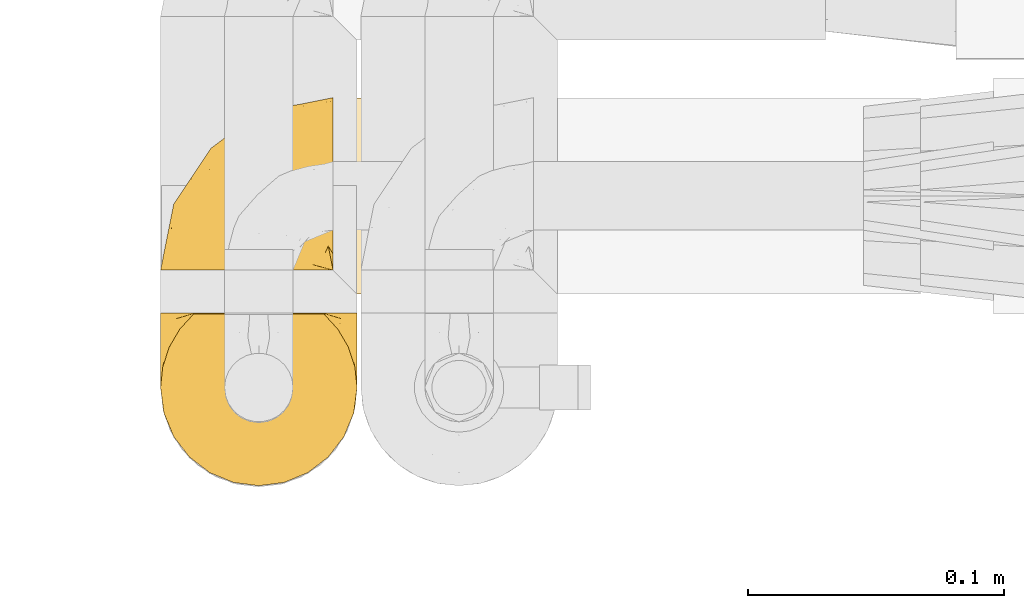
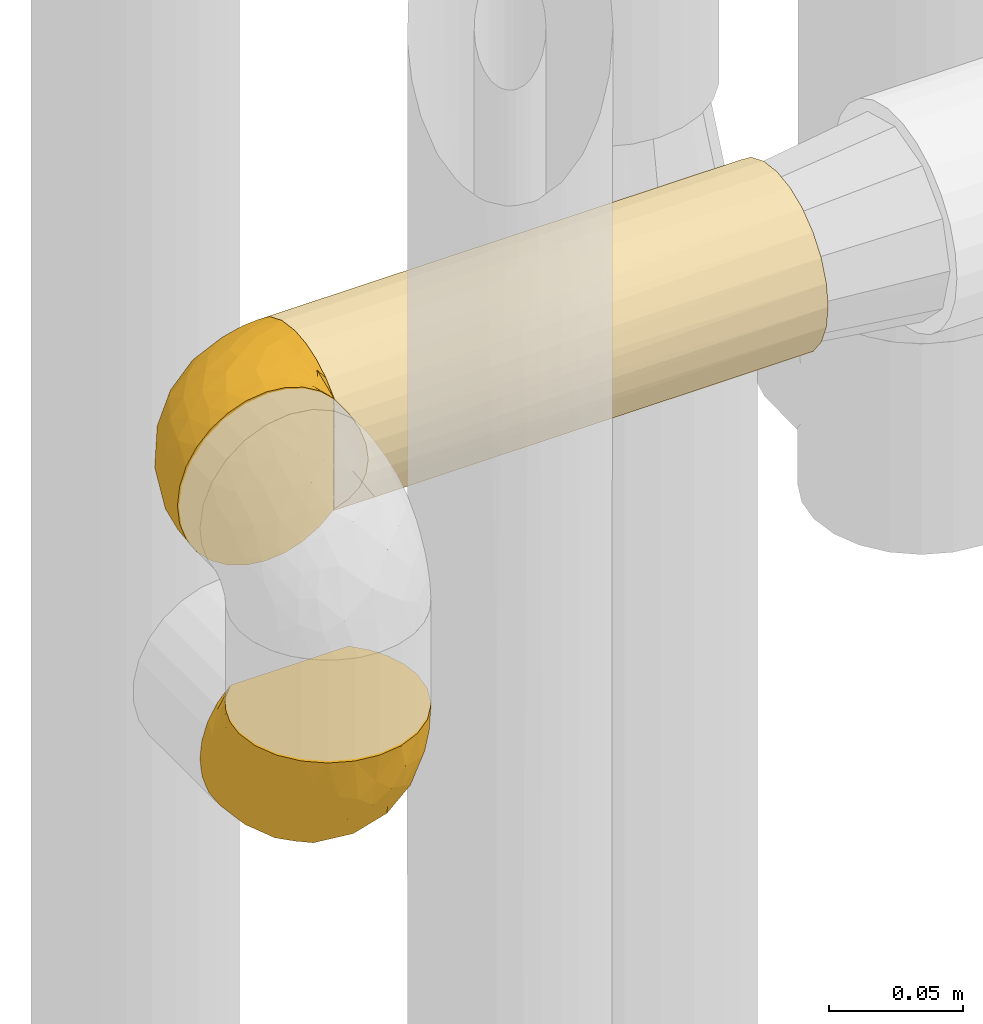
# One storey, part 466 of 827: 3 coverings.
"""IFC2X3 building model written with IfcOpenShell, lengths in millimetres."""

import ifcopenshell
import ifcopenshell.guid

model = None  # the IFC model being written
_history = None  # IfcOwnerHistory: only IFC2X3 demands one
_inside = {}  # id of a spatial element -> (the spatial element, [elements in it])
_under = {}  # id of a project, library or spatial element -> (it, [spatial elements below it])
_declared = {}  # id of a project -> (the project, [libraries it declares])
_typed = {}  # id of a type object -> (the type object, [elements of that type])
_made_of = {}  # id of a material, layer set ... -> (it, [elements and type objects made of it])


def new_model(schema):
    """Start an empty IFC model of exactly this schema.

    Asked for "IFC4X3", IfcOpenShell would pick the latest addendum, in which some entities
    have other attributes; the version numbers below select the first issue.
    IFC2X3 requires an IfcOwnerHistory on every rooted entity: one is made here for all.
    """
    global model, _history
    if schema == "IFC4X3":
        model = ifcopenshell.file(schema_version=(4, 3, 0, 0))
    else:
        model = ifcopenshell.file(schema=schema)
    _inside.clear()
    _under.clear()
    _declared.clear()
    _typed.clear()
    _made_of.clear()
    _history = None
    if model.schema == "IFC2X3":
        org = make("IfcOrganization", Name="unknown")
        user = make(
            "IfcPersonAndOrganization",
            ThePerson=make("IfcPerson", FamilyName="unknown"),
            TheOrganization=org,
        )
        app = make(
            "IfcApplication",
            ApplicationDeveloper=org,
            Version="unknown",
            ApplicationFullName="unknown",
            ApplicationIdentifier="unknown",
        )
        _history = make(
            "IfcOwnerHistory",
            OwningUser=user,
            OwningApplication=app,
            ChangeAction="ADDED",
            CreationDate=0,
        )
    return model


def make(cls, **values):
    """One entity of the class cls with the attributes given. An attribute that is None is left unset."""
    return model.create_entity(
        cls, **{name: value for name, value in values.items() if value is not None}
    )


def entity(cls, *values):
    """Any entity or typed value of the class cls, its attributes in the order of the schema. None: left unset."""
    e = model.create_entity(cls)
    for i, value in enumerate(values):
        if value is not None:
            e[i] = value
    return e


def rooted(cls, **values):
    """An entity with a GlobalId (a new one), such as an element, a storey or a relation."""
    return make(cls, GlobalId=ifcopenshell.guid.new(), OwnerHistory=_history, **values)


def si_unit(unit_type, name, prefix=None):
    """IfcSIUnit, for example si_unit("LENGTHUNIT", "METRE", prefix="MILLI")."""
    return make("IfcSIUnit", UnitType=unit_type, Prefix=prefix, Name=name)


def converted_unit(unit_type, name, factor, base, dimensions=None, offset=None):
    """IfcConversionBasedUnit, such as the inch: factor (a typed value) times the base unit."""
    return make(
        "IfcConversionBasedUnit"
        if offset is None
        else "IfcConversionBasedUnitWithOffset",
        ConversionOffset=offset,
        Dimensions=None
        if dimensions is None
        else entity("IfcDimensionalExponents", *dimensions),
        UnitType=unit_type,
        Name=name,
        ConversionFactor=make(
            "IfcMeasureWithUnit", ValueComponent=factor, UnitComponent=base
        ),
    )


def derived_unit(unit_type, elements):
    """IfcDerivedUnit: a product of units, each with its exponent."""
    return make(
        "IfcDerivedUnit",
        Elements=[
            make("IfcDerivedUnitElement", Unit=unit, Exponent=power)
            for unit, power in elements
        ],
        UnitType=unit_type,
    )


def assignment(units):
    """IfcUnitAssignment: the units of a project."""
    return None if units is None else make("IfcUnitAssignment", Units=units)


def point(xyz):
    """IfcCartesianPoint."""
    return None if xyz is None else make("IfcCartesianPoint", Coordinates=xyz)


def direction(xyz):
    """IfcDirection."""
    return None if xyz is None else make("IfcDirection", DirectionRatios=xyz)


def frame(location, z_axis=None, x_axis=None):
    """IfcAxis2Placement3D, a coordinate frame: its origin and axes. An axis left out is left unset."""
    return make(
        "IfcAxis2Placement3D",
        Location=point(location),
        Axis=direction(z_axis),
        RefDirection=direction(x_axis),
    )


def origin():
    """The frame at (0, 0, 0) with its axes left unset."""
    return frame((0.0, 0.0, 0.0))


def place(relative_to, where):
    """IfcLocalPlacement: puts the frame where relative to a parent placement (None: the world)."""
    return make(
        "IfcLocalPlacement", PlacementRelTo=relative_to, RelativePlacement=where
    )


def context(
    kind, dimensions, precision=None, world=None, true_north=None, identifier=None
):
    """IfcGeometricRepresentationContext, for example the 3D "Model" context."""
    return make(
        "IfcGeometricRepresentationContext",
        ContextIdentifier=identifier,
        ContextType=kind,
        CoordinateSpaceDimension=dimensions,
        Precision=precision,
        WorldCoordinateSystem=world,
        TrueNorth=true_north,
    )


def subcontext(parent, identifier, kind, view, scale=None):
    """IfcGeometricRepresentationSubContext, for example "Body" below "Model"."""
    return make(
        "IfcGeometricRepresentationSubContext",
        ContextIdentifier=identifier,
        ContextType=kind,
        ParentContext=parent,
        TargetScale=scale,
        TargetView=view,
    )


def project(units=None, contexts=None):
    """IfcProject with its units and contexts."""
    return rooted(
        "IfcProject",
        Name="project",
        RepresentationContexts=contexts,
        UnitsInContext=assignment(units),
    )


def spatial(cls, under=None, at=None, **own):
    """A site, building, storey or space (cls), placed at a placement, below another one or the project."""
    s = rooted(cls, ObjectPlacement=at, **own)
    if under is not None:
        _under.setdefault(under.id(), (under, []))[1].append(s)
    return s


def faces_of(points, faces, orient=None, outer=None):
    """IfcFace entities. A face is a list of loops; a loop is a list of indices into points, from 0.

    orient and outer hold one flag for each loop. By default every Orientation is true, the
    first loop of a face is its IfcFaceOuterBound and the others are IfcFaceBound.
    """
    made = []
    for i, loops in enumerate(faces):
        bounds = []
        for j, loop in enumerate(loops):
            is_outer = j == 0 if outer is None else outer[i][j]
            bounds.append(
                make(
                    "IfcFaceOuterBound" if is_outer else "IfcFaceBound",
                    Bound=make("IfcPolyLoop", Polygon=[points[k] for k in loop]),
                    Orientation=True if orient is None else orient[i][j],
                )
            )
        made.append(make("IfcFace", Bounds=bounds))
    return made


def faceted_brep(points, faces, orient=None, outer=None, voids=None):
    """IfcFacetedBrep: a solid bounded by flat faces; with voids (closed shells), ...WithVoids."""
    shared = [point(p) for p in points]
    hull = make("IfcClosedShell", CfsFaces=faces_of(shared, faces, orient, outer))
    if voids is None:
        return make("IfcFacetedBrep", Outer=hull)
    return make(
        "IfcFacetedBrepWithVoids",
        Outer=hull,
        Voids=[
            make(cls, CfsFaces=faces_of(shared, fs, o, b)) for cls, fs, o, b in voids
        ],
    )


def shape(context_of_items, identifier, shape_type, items):
    """IfcShapeRepresentation: the items that make up one representation, for example the "Body"."""
    return make(
        "IfcShapeRepresentation",
        ContextOfItems=context_of_items,
        RepresentationIdentifier=identifier,
        RepresentationType=shape_type,
        Items=items,
    )


def made_of(thing, what):
    """Note that an element or type object is made of a material, layer set ...; save() writes the relation."""
    if what is not None:
        _made_of.setdefault(what.id(), (what, []))[1].append(thing)
    return thing


def element(
    cls,
    number,
    at=None,
    inside=None,
    cuts=None,
    type_object=None,
    material=None,
    context=None,
    identifier="Body",
    shape_type=None,
    held_by="IfcProductDefinitionShape",
    body=None,
    shapes=None,
    **own,
):
    """One element of the class cls, such as IfcWall. Its Tag is "e" and its number.

    at: its placement. inside: the storey or other place that contains it. cuts: it is an
    opening in that element (IfcRelVoidsElement). A single representation is given by context,
    identifier, shape_type and body (its items); several are given by shapes. held_by: the class
    of the entity that holds the representations. save() writes the other relations.
    """
    e = rooted(cls, Tag="e%d" % number, ObjectPlacement=at, **own)
    if body is not None:
        shapes = [shape(context, identifier, shape_type, body)]
    if shapes is not None:
        e.Representation = make(held_by, Representations=shapes)
    if inside is not None:
        _inside.setdefault(inside.id(), (inside, []))[1].append(e)
    if cuts is not None:
        rooted(
            "IfcRelVoidsElement", RelatingBuildingElement=cuts, RelatedOpeningElement=e
        )
    if type_object is not None:
        _typed.setdefault(type_object.id(), (type_object, []))[1].append(e)
    return made_of(e, material)


def aggregate(whole, parts):
    """IfcRelAggregates: a whole, such as a stair, and the parts it consists of."""
    return rooted("IfcRelAggregates", RelatingObject=whole, RelatedObjects=parts)


def save(model, path):
    """Write the relations noted so far, then the file.

    IfcRelAggregates (storeys below a building ...), IfcRelContainedInSpatialStructure (elements
    in a storey), IfcRelDefinesByType, IfcRelAssociatesMaterial and IfcRelDeclares: one each for
    every whole, place, type object, material and project.
    """
    for whole, parts in _under.values():
        aggregate(whole, parts)
    for where, things in _inside.values():
        rooted(
            "IfcRelContainedInSpatialStructure",
            RelatedElements=things,
            RelatingStructure=where,
        )
    for kind, things in _typed.values():
        rooted("IfcRelDefinesByType", RelatedObjects=things, RelatingType=kind)
    for what, things in _made_of.values():
        rooted("IfcRelAssociatesMaterial", RelatedObjects=things, RelatingMaterial=what)
    for by, libraries in _declared.values():
        rooted("IfcRelDeclares", RelatingContext=by, RelatedDefinitions=libraries)
    model.write(path)


model = new_model("IFC2X3")

# Units and contexts
model_context = context("Model", 3, precision=0.01, world=origin(), true_north=direction((6.12303176911189e-17, 1.0)))
body_context = subcontext(model_context, "Body", "Model", "MODEL_VIEW")
ifc_project = project(units=[si_unit("LENGTHUNIT", "METRE", prefix="MILLI"), si_unit("AREAUNIT", "SQUARE_METRE"), si_unit("VOLUMEUNIT", "CUBIC_METRE"), converted_unit("PLANEANGLEUNIT", "DEGREE", entity("IfcRatioMeasure", 0.0174532925199433), si_unit("PLANEANGLEUNIT", "RADIAN"), dimensions=[0, 0, 0, 0, 0, 0, 0]), si_unit("MASSUNIT", "GRAM", prefix="KILO"), derived_unit("MASSDENSITYUNIT", [(si_unit("MASSUNIT", "GRAM", prefix="KILO"), 1), (si_unit("LENGTHUNIT", "METRE"), -3)]), derived_unit("MOMENTOFINERTIAUNIT", [(si_unit("LENGTHUNIT", "METRE"), 4)]), si_unit("TIMEUNIT", "SECOND"), si_unit("FREQUENCYUNIT", "HERTZ"), si_unit("THERMODYNAMICTEMPERATUREUNIT", "DEGREE_CELSIUS"), derived_unit("THERMALTRANSMITTANCEUNIT", [(si_unit("MASSUNIT", "GRAM", prefix="KILO"), 1), (si_unit("THERMODYNAMICTEMPERATUREUNIT", "KELVIN"), -1), (si_unit("TIMEUNIT", "SECOND"), -3)]), derived_unit("VOLUMETRICFLOWRATEUNIT", [(si_unit("LENGTHUNIT", "METRE"), 3), (si_unit("TIMEUNIT", "SECOND"), -1)]), derived_unit("MASSFLOWRATEUNIT", [(si_unit("MASSUNIT", "GRAM", prefix="KILO"), 1), (si_unit("TIMEUNIT", "SECOND"), -1)]), derived_unit("ROTATIONALFREQUENCYUNIT", [(si_unit("TIMEUNIT", "SECOND"), -1)]), si_unit("ELECTRICCURRENTUNIT", "AMPERE"), si_unit("ELECTRICVOLTAGEUNIT", "VOLT"), si_unit("POWERUNIT", "WATT"), si_unit("FORCEUNIT", "NEWTON", prefix="KILO"), si_unit("ILLUMINANCEUNIT", "LUX"), si_unit("LUMINOUSFLUXUNIT", "LUMEN"), si_unit("LUMINOUSINTENSITYUNIT", "CANDELA"), derived_unit("USERDEFINED", [(si_unit("MASSUNIT", "GRAM", prefix="KILO"), -1), (si_unit("LENGTHUNIT", "METRE"), -2), (si_unit("TIMEUNIT", "SECOND"), 3), (si_unit("LUMINOUSFLUXUNIT", "LUMEN"), 1)]), derived_unit("LINEARVELOCITYUNIT", [(si_unit("LENGTHUNIT", "METRE"), 1), (si_unit("TIMEUNIT", "SECOND"), -1)]), si_unit("PRESSUREUNIT", "PASCAL"), derived_unit("USERDEFINED", [(si_unit("LENGTHUNIT", "METRE"), -2), (si_unit("MASSUNIT", "GRAM", prefix="KILO"), 1), (si_unit("TIMEUNIT", "SECOND"), -2)]), derived_unit("LINEARFORCEUNIT", [(si_unit("MASSUNIT", "GRAM", prefix="KILO"), 1), (si_unit("LENGTHUNIT", "METRE"), 1), (si_unit("TIMEUNIT", "SECOND"), -2), (si_unit("LENGTHUNIT", "METRE"), -1)]), derived_unit("PLANARFORCEUNIT", [(si_unit("MASSUNIT", "GRAM", prefix="KILO"), 1), (si_unit("LENGTHUNIT", "METRE"), 1), (si_unit("TIMEUNIT", "SECOND"), -2), (si_unit("LENGTHUNIT", "METRE"), -2)])], contexts=[model_context])

# Site, building, storey
site_placement = place(None, origin())
site = spatial("IfcSite", under=ifc_project, at=site_placement, CompositionType="ELEMENT")
building_placement = place(site_placement, origin())
building = spatial("IfcBuilding", under=site, at=building_placement, CompositionType="ELEMENT")
storey_placement = place(building_placement, frame((0.0, 0.0, 28200.0)))
storey = spatial("IfcBuildingStorey", under=building, at=storey_placement, Name="08", CompositionType="ELEMENT", Elevation=28200.0)

# Coverings
covering_1_placement = place(storey_placement, frame((58451.15, 16264.79, 2254.95)))
element("IfcCovering", 1, at=covering_1_placement, inside=storey, Name=":ADSK_", ObjectType=":ADSK_", PredefinedType="INSULATION", context=body_context, shape_type="Brep", body=[
    faceted_brep([(74.68, 69.15, 23.36), (70.1, 69.15, 16.07), (64.01, 69.15, 9.98), (56.72, 69.15, 5.4), (48.6, 69.15, 2.56), (40.05, 69.15, 1.6), (31.49, 69.15, 2.56), (23.36, 69.15, 5.41), (16.07, 69.15, 9.99), (9.98, 69.15, 16.08), (5.4, 69.15, 23.37), (2.56, 69.15, 31.49), (1.6, 69.15, 40.05), (2.46, 69.15, 48.15), (5.01, 69.15, 55.88), (9.13, 69.15, 62.9), (14.62, 69.15, 68.89), (16.82, 69.15, 68.89), (18.56, 69.15, 68.89), (20.52, 69.15, 68.89), (22.49, 69.15, 68.89), (24.46, 69.15, 68.89), (26.42, 69.15, 68.89), (28.39, 69.15, 68.89), (30.36, 69.15, 68.89), (32.55, 69.15, 68.89), (34.75, 69.15, 68.89), (36.94, 69.15, 68.89), (39.13, 69.15, 68.89), (41.33, 69.15, 68.89), (43.52, 69.15, 68.89), (45.72, 69.15, 68.89), (47.91, 69.15, 68.89), (50.11, 69.15, 68.89), (52.3, 69.15, 68.89), (54.49, 69.15, 68.89), (56.69, 69.15, 68.89), (58.88, 69.15, 68.89), (61.08, 69.15, 68.89), (63.27, 69.15, 68.89), (65.47, 69.15, 68.89), (70.97, 69.15, 62.89), (75.09, 69.15, 55.86), (77.64, 69.15, 48.13), (78.5, 69.15, 40.05), (77.53, 69.15, 31.49), (14.62, 68.89, 69.15), (9.12, 62.89, 69.15), (5.0, 55.87, 69.15), (2.46, 48.14, 69.15), (1.6, 40.05, 69.15), (2.91, 30.09, 69.15), (6.75, 20.82, 69.15), (12.86, 12.86, 69.15), (20.82, 6.75, 69.15), (30.09, 2.91, 69.15), (40.05, 1.6, 69.15), (50.0, 2.91, 69.15), (59.27, 6.75, 69.15), (67.23, 12.86, 69.15), (73.34, 20.82, 69.15), (77.19, 30.09, 69.15), (78.5, 40.05, 69.15), (77.63, 48.14, 69.15), (75.09, 55.87, 69.15), (70.97, 62.89, 69.15), (65.47, 68.89, 69.15), (63.27, 68.89, 69.15), (62.29, 68.89, 69.15), (60.7, 68.89, 69.15), (59.11, 68.89, 69.15), (57.52, 68.89, 69.15), (55.93, 68.89, 69.15), (54.34, 68.89, 69.15), (52.76, 68.89, 69.15), (51.17, 68.89, 69.15), (49.58, 68.89, 69.15), (47.99, 68.89, 69.15), (46.4, 68.89, 69.15), (44.81, 68.89, 69.15), (43.22, 68.89, 69.15), (41.63, 68.89, 69.15), (40.05, 68.89, 69.15), (38.46, 68.89, 69.15), (36.87, 68.89, 69.15), (35.28, 68.89, 69.15), (33.69, 68.89, 69.15), (32.1, 68.89, 69.15), (30.51, 68.89, 69.15), (28.92, 68.89, 69.15), (27.33, 68.89, 69.15), (25.37, 68.89, 69.15), (23.4, 68.89, 69.15), (21.21, 68.89, 69.15), (19.01, 68.89, 69.15), (16.82, 68.89, 69.15), (42.32, 68.97, 68.96), (44.02, 68.96, 68.97), (47.13, 68.97, 68.97), (48.74, 68.97, 68.97), (23.57, 68.98, 68.95), (25.13, 68.97, 68.96), (61.34, 68.96, 68.98), (22.02, 68.96, 68.97), (29.72, 68.96, 68.97), (56.73, 68.96, 68.98), (55.14, 68.96, 68.97), (37.66, 68.96, 68.97), (64.12, 69.0, 68.94), (28.13, 68.96, 68.98), (26.62, 68.96, 68.98), (31.46, 68.97, 68.96), (16.16, 68.96, 68.97), (39.16, 68.96, 68.98), (50.37, 68.96, 68.98), (17.69, 68.97, 68.97), (19.17, 68.97, 68.96), (62.78, 68.97, 68.97), (58.35, 68.96, 68.97), (45.53, 68.96, 68.98), (59.91, 68.97, 68.96), (65.47, 68.97, 68.97), (65.47, 69.02, 68.94), (65.47, 69.08, 68.92), (14.62, 68.97, 68.97), (14.62, 68.94, 69.02), (14.62, 68.92, 69.08), (20.59, 68.96, 68.98), (32.99, 68.96, 68.97), (34.48, 68.95, 68.98), (51.91, 68.96, 68.97), (65.47, 68.92, 69.08), (65.47, 68.94, 69.02), (53.48, 68.98, 68.96), (14.62, 69.08, 68.92), (14.62, 69.02, 68.94), (40.77, 68.96, 68.97), (35.97, 68.97, 68.96), (7.84, 61.33, 67.02), (3.53, 53.1, 63.33), (8.32, 63.33, 64.61), (2.19, 55.53, 51.4), (3.53, 63.33, 53.1), (1.6, 54.6, 43.94), (1.6, 41.99, 61.87), (4.57, 57.07, 61.54), (3.96, 57.95, 57.95), (2.28, 51.56, 56.12), (1.6, 41.58, 63.4), (7.69, 61.7, 65.41), (8.32, 65.0, 63.04), (7.84, 67.02, 61.33), (1.6, 61.87, 41.99), (1.6, 49.27, 49.27), (1.6, 43.94, 54.6), (4.34, 61.21, 56.6), (1.6, 63.4, 41.58), (29.63, 33.11, 13.72), (27.34, 52.82, 5.82), (40.05, 43.3, 6.74), (2.39, 33.73, 58.82), (2.43, 36.52, 51.58), (9.07, 24.87, 42.09), (16.64, 14.17, 46.12), (9.54, 18.43, 55.56), (4.52, 28.67, 52.38), (4.52, 26.0, 61.54), (7.49, 49.25, 23.76), (7.49, 59.72, 20.5), (12.85, 55.1, 14.64), (2.35, 44.72, 41.77), (22.66, 34.15, 16.28), (32.9, 5.25, 49.4), (25.33, 6.75, 52.34), (40.05, 55.54, 4.3), (16.64, 10.47, 58.67), (19.99, 25.49, 25.26), (16.37, 35.53, 20.17), (3.26, 48.22, 34.7), (3.75, 58.71, 28.67), (19.58, 57.42, 8.62), (7.5, 34.84, 33.37), (4.04, 36.87, 41.35), (13.94, 45.01, 17.15), (19.58, 44.4, 12.68), (28.21, 23.96, 21.47), (24.75, 11.2, 41.11), (31.42, 10.56, 37.53), (26.2, 16.81, 30.64), (33.36, 17.38, 26.66), (40.05, 21.38, 21.38), (40.05, 32.34, 14.06), (40.05, 4.3, 55.54), (16.14, 20.65, 35.17), (12.85, 29.66, 29.04), (10.47, 39.6, 24.34), (6.49, 42.55, 29.33), (40.05, 6.74, 43.3), (40.05, 14.06, 32.34), (75.57, 26.84, 57.75), (47.37, 5.28, 49.41), (52.91, 18.52, 27.85), (50.46, 33.13, 13.7), (67.23, 55.1, 14.63), (60.5, 57.43, 8.61), (70.55, 20.72, 48.85), (63.45, 11.46, 54.13), (62.61, 17.69, 37.84), (72.6, 49.26, 23.75), (72.6, 59.73, 20.49), (76.34, 58.71, 28.66), (59.34, 29.72, 20.83), (77.76, 35.35, 55.15), (78.5, 43.94, 54.6), (78.5, 41.99, 61.87), (78.5, 63.4, 41.58), (53.16, 4.93, 57.58), (70.55, 17.46, 59.91), (48.88, 10.94, 36.94), (54.76, 8.92, 45.72), (52.74, 52.83, 5.82), (71.93, 29.34, 37.91), (75.79, 30.26, 50.18), (60.5, 44.4, 12.67), (77.86, 39.06, 49.29), (77.64, 43.06, 42.64), (78.5, 54.6, 43.94), (78.5, 49.27, 49.27), (67.23, 42.69, 19.45), (76.82, 48.2, 34.7), (78.5, 61.87, 41.99), (77.8, 33.44, 62.29), (67.23, 29.67, 29.01), (73.2, 38.5, 31.47), (67.66, 23.35, 37.18), (75.99, 34.97, 43.45), (76.57, 53.1, 63.33), (73.21, 59.68, 67.23), (71.93, 62.19, 66.07), (71.07, 64.11, 65.22), (75.09, 57.97, 61.99), (76.13, 57.95, 57.95), (76.57, 63.33, 53.09), (77.69, 51.77, 56.84), (72.26, 67.02, 61.33), (71.77, 64.98, 63.06), (77.9, 55.53, 51.41), (75.75, 61.22, 56.61)], [[[0, 1, 2, 3, 4, 5, 6, 7, 8, 9, 10, 11, 12, 13, 14, 15, 16, 17, 18, 19, 20, 21, 22, 23, 24, 25, 26, 27, 28, 29, 30, 31, 32, 33, 34, 35, 36, 37, 38, 39, 40, 41, 42, 43, 44, 45]], [[46, 47, 48, 49, 50, 51, 52, 53, 54, 55, 56, 57, 58, 59, 60, 61, 62, 63, 64, 65, 66, 67, 68, 69, 70, 71, 72, 73, 74, 75, 76, 77, 78, 79, 80, 81, 82, 83, 84, 85, 86, 87, 88, 89, 90, 91, 92, 93, 94, 95]], [[96, 97, 30]], [[98, 77, 99]], [[100, 101, 21]], [[69, 68, 102]], [[20, 19, 103]], [[24, 23, 104]], [[20, 103, 100]], [[72, 105, 106]], [[84, 83, 107]], [[89, 88, 104]], [[108, 67, 66]], [[109, 110, 90]], [[111, 25, 24]], [[112, 17, 16]], [[82, 113, 83]], [[109, 23, 22]], [[114, 76, 75]], [[105, 36, 106]], [[104, 111, 24]], [[18, 115, 116]], [[97, 96, 80]], [[67, 108, 117]], [[105, 71, 118]], [[31, 97, 119]], [[102, 120, 69]], [[108, 121, 122, 123, 40]], [[112, 95, 115]], [[17, 115, 18]], [[94, 116, 115]], [[117, 68, 67]], [[38, 117, 39]], [[112, 124, 125, 126, 46]], [[17, 112, 115]], [[70, 120, 118]], [[39, 117, 108]], [[120, 38, 37]], [[120, 37, 118]], [[120, 70, 69]], [[116, 94, 127]], [[128, 86, 129]], [[117, 38, 102]], [[74, 130, 75]], [[99, 33, 32]], [[115, 95, 94]], [[39, 108, 40]], [[108, 66, 131, 132, 121]], [[105, 72, 71]], [[118, 37, 36]], [[71, 70, 118]], [[35, 106, 36]], [[36, 105, 118]], [[35, 133, 106]], [[74, 73, 133]], [[106, 133, 73]], [[99, 114, 33]], [[133, 35, 34]], [[73, 72, 106]], [[95, 112, 46]], [[112, 16, 134, 135, 124]], [[130, 114, 75]], [[99, 76, 114]], [[114, 130, 33]], [[34, 33, 130]], [[78, 77, 98]], [[98, 119, 78]], [[130, 133, 34]], [[133, 130, 74]], [[79, 97, 80]], [[98, 99, 32]], [[98, 32, 31]], [[77, 76, 99]], [[97, 79, 119]], [[136, 96, 29]], [[30, 97, 31]], [[136, 29, 28]], [[81, 80, 96]], [[29, 96, 30]], [[31, 119, 98]], [[119, 79, 78]], [[96, 136, 81]], [[82, 81, 136]], [[113, 107, 83]], [[84, 107, 137]], [[107, 27, 137]], [[113, 28, 107]], [[27, 107, 28]], [[85, 84, 137]], [[137, 27, 26]], [[113, 136, 28]], [[136, 113, 82]], [[109, 89, 104]], [[86, 85, 129]], [[89, 109, 90]], [[111, 87, 128]], [[26, 129, 137]], [[88, 111, 104]], [[25, 111, 128]], [[22, 110, 109]], [[23, 109, 104]], [[110, 91, 90]], [[100, 92, 101]], [[110, 22, 101]], [[91, 110, 101]], [[116, 19, 18]], [[111, 88, 87]], [[127, 103, 19]], [[25, 128, 26]], [[86, 128, 87]], [[128, 129, 26]], [[137, 129, 85]], [[120, 102, 38]], [[117, 102, 68]], [[91, 101, 92]], [[21, 101, 22]], [[93, 92, 103]], [[100, 21, 20]], [[100, 103, 92]], [[127, 93, 103]], [[93, 127, 94]], [[116, 127, 19]], [[126, 138, 47]], [[48, 138, 139]], [[140, 125, 124]], [[141, 142, 143]], [[144, 49, 139]], [[145, 140, 146]], [[48, 139, 49]], [[139, 145, 147]], [[49, 144, 148, 50]], [[126, 125, 149]], [[14, 13, 142]], [[150, 146, 140]], [[149, 140, 145]], [[151, 150, 135]], [[151, 14, 142]], [[16, 15, 134]], [[13, 152, 142]], [[124, 150, 140]], [[141, 143, 153]], [[14, 151, 15]], [[15, 151, 134]], [[47, 46, 126]], [[139, 154, 144]], [[138, 48, 47]], [[125, 140, 149]], [[135, 134, 151]], [[146, 155, 141]], [[145, 146, 147]], [[149, 139, 138]], [[147, 153, 154]], [[147, 146, 141]], [[139, 147, 154]], [[139, 149, 145]], [[149, 138, 126]], [[147, 141, 153]], [[146, 150, 155]], [[151, 155, 150]], [[142, 141, 155]], [[13, 12, 156, 152]], [[152, 143, 142]], [[151, 142, 155]], [[150, 124, 135]], [[157, 158, 159]], [[160, 154, 161]], [[162, 163, 164]], [[165, 166, 160]], [[167, 168, 169]], [[153, 170, 161]], [[156, 12, 11]], [[158, 157, 171]], [[172, 55, 173]], [[158, 6, 174]], [[175, 54, 53]], [[52, 166, 164]], [[52, 164, 53]], [[54, 175, 173]], [[166, 52, 51]], [[176, 177, 171]], [[178, 143, 179]], [[156, 11, 179]], [[8, 7, 180]], [[169, 9, 8]], [[179, 143, 152, 156]], [[179, 11, 10]], [[168, 179, 10]], [[181, 162, 182]], [[179, 167, 178]], [[183, 184, 177]], [[183, 169, 184]], [[176, 171, 185]], [[172, 186, 187]], [[158, 7, 6]], [[159, 158, 174]], [[184, 180, 158]], [[54, 173, 55]], [[180, 169, 8]], [[188, 189, 187]], [[9, 168, 10]], [[186, 188, 187]], [[190, 157, 159, 191]], [[55, 172, 192]], [[176, 193, 194]], [[161, 170, 182]], [[162, 164, 165]], [[175, 164, 163]], [[51, 50, 148]], [[167, 195, 196]], [[178, 182, 170]], [[6, 5, 174]], [[158, 180, 7]], [[169, 180, 184]], [[169, 168, 9]], [[179, 168, 167]], [[182, 162, 165]], [[162, 194, 193]], [[161, 165, 160]], [[195, 181, 196]], [[192, 172, 197]], [[192, 56, 55]], [[189, 190, 198]], [[198, 197, 187]], [[172, 187, 197]], [[185, 189, 188]], [[198, 187, 189]], [[186, 172, 173]], [[173, 163, 186]], [[193, 186, 163]], [[176, 185, 188]], [[185, 157, 190]], [[188, 186, 193]], [[177, 176, 194]], [[188, 193, 176]], [[162, 193, 163]], [[195, 177, 194]], [[171, 177, 184]], [[181, 195, 194]], [[183, 167, 169]], [[162, 181, 194]], [[196, 182, 178]], [[158, 171, 184]], [[171, 157, 185]], [[177, 195, 183]], [[167, 183, 195]], [[182, 196, 181]], [[178, 170, 143]], [[178, 167, 196]], [[164, 175, 53]], [[173, 175, 163]], [[160, 51, 148]], [[164, 166, 165]], [[51, 160, 166]], [[160, 148, 144, 154]], [[153, 161, 154]], [[182, 165, 161]], [[190, 189, 185]], [[143, 170, 153]], [[60, 199, 61]], [[197, 200, 192]], [[201, 190, 202]], [[200, 57, 192]], [[203, 204, 2]], [[205, 206, 207]], [[208, 209, 210]], [[211, 207, 201]], [[212, 213, 214]], [[45, 215, 210]], [[216, 206, 58]], [[45, 44, 215]], [[59, 217, 60]], [[60, 217, 199]], [[0, 45, 210]], [[218, 201, 219]], [[202, 159, 220]], [[205, 221, 222]], [[223, 204, 203]], [[1, 203, 2]], [[57, 200, 216]], [[220, 3, 204]], [[220, 174, 4]], [[1, 0, 209]], [[212, 224, 213]], [[225, 226, 227]], [[228, 223, 203]], [[208, 210, 229]], [[210, 226, 229]], [[3, 220, 4]], [[58, 206, 59]], [[209, 203, 1]], [[202, 220, 223]], [[228, 203, 208]], [[202, 211, 201]], [[3, 2, 204]], [[202, 190, 191, 159]], [[210, 215, 230, 226]], [[199, 212, 231]], [[232, 233, 221]], [[233, 208, 229]], [[207, 206, 219]], [[217, 206, 205]], [[227, 224, 225]], [[233, 232, 228]], [[201, 207, 219]], [[234, 232, 221]], [[218, 219, 200]], [[202, 223, 211]], [[174, 220, 159]], [[174, 5, 4]], [[61, 231, 62]], [[220, 204, 223]], [[210, 209, 0]], [[203, 209, 208]], [[225, 233, 229]], [[224, 227, 213]], [[221, 233, 235]], [[57, 56, 192]], [[198, 218, 197]], [[200, 219, 216]], [[201, 198, 190]], [[197, 218, 200]], [[198, 201, 218]], [[206, 216, 219]], [[58, 57, 216]], [[231, 212, 214]], [[222, 212, 199]], [[228, 211, 223]], [[207, 211, 232]], [[62, 231, 214]], [[199, 231, 61]], [[233, 228, 208]], [[211, 228, 232]], [[222, 221, 235]], [[234, 205, 207]], [[206, 217, 59]], [[199, 217, 205]], [[205, 222, 199]], [[224, 222, 235]], [[222, 224, 212]], [[224, 235, 225]], [[233, 225, 235]], [[226, 225, 229]], [[205, 234, 221]], [[207, 232, 234]], [[63, 214, 236]], [[214, 213, 236]], [[214, 63, 62]], [[237, 236, 238]], [[238, 132, 131]], [[236, 237, 64]], [[239, 240, 241]], [[63, 236, 64]], [[131, 66, 65]], [[237, 131, 65]], [[242, 230, 43]], [[237, 65, 64]], [[239, 121, 132]], [[42, 242, 43]], [[241, 240, 243]], [[41, 123, 244]], [[43, 230, 215, 44]], [[244, 122, 245]], [[227, 246, 243]], [[241, 243, 246]], [[121, 239, 245]], [[41, 40, 123]], [[132, 238, 239]], [[244, 42, 41]], [[131, 237, 238]], [[240, 239, 238]], [[245, 239, 241]], [[247, 241, 246]], [[247, 244, 245]], [[238, 236, 240]], [[243, 236, 213]], [[236, 243, 240]], [[226, 246, 227]], [[243, 213, 227]], [[226, 242, 246]], [[241, 247, 245]], [[246, 242, 247]], [[244, 247, 242]], [[242, 226, 230]], [[42, 244, 242]], [[122, 244, 123]], [[122, 121, 245]]]),
])
covering_2_placement = place(storey_placement, frame((58518.7, 16339.84, 2360.0)))
element("IfcCovering", 2, at=covering_2_placement, inside=storey, Name=":ADSK_", ObjectType=":ADSK_", PredefinedType="INSULATION", context=body_context, shape_type="Brep", body=[
    faceted_brep([(209.12, 73.25, 20.8), (209.12, 77.09, 30.06), (209.12, 78.4, 40.0), (209.12, 77.09, 49.93), (209.12, 73.25, 59.2), (209.12, 67.15, 67.15), (209.12, 59.2, 73.25), (209.12, 49.93, 77.09), (209.12, 40.0, 78.4), (209.12, 30.06, 77.09), (209.12, 20.8, 73.25), (209.12, 12.84, 67.15), (209.12, 6.74, 59.2), (209.12, 2.9, 49.93), (209.12, 1.6, 40.0), (209.12, 2.9, 30.06), (209.12, 6.74, 20.8), (209.12, 12.84, 12.84), (209.12, 20.8, 6.74), (209.12, 30.06, 2.9), (209.12, 40.0, 1.6), (209.12, 49.93, 2.9), (209.12, 59.2, 6.74), (209.12, 67.15, 12.84), (1.6, 77.09, 30.06), (1.6, 73.25, 20.8), (1.6, 67.15, 12.84), (1.6, 59.2, 6.74), (1.6, 49.93, 2.9), (1.6, 40.0, 1.6), (1.6, 31.79, 2.48), (1.6, 23.98, 5.09), (1.6, 16.91, 9.31), (1.6, 10.9, 14.94), (1.6, 10.9, 65.05), (1.6, 16.91, 70.68), (1.6, 23.98, 74.9), (1.6, 31.79, 77.51), (1.6, 40.0, 78.4), (1.6, 49.93, 77.09), (1.6, 59.2, 73.25), (1.6, 67.15, 67.15), (1.6, 73.25, 59.2), (1.6, 77.09, 49.93), (1.6, 78.4, 40.0), (10.29, 2.2, 33.21), (8.5, 4.0, 26.63), (5.57, 6.92, 20.48), (10.9, 1.6, 40.0), (5.57, 6.92, 59.51), (8.5, 4.0, 53.36), (10.29, 2.2, 46.78)], [[[0, 1, 2, 3, 4, 5, 6, 7, 8, 9, 10, 11, 12, 13, 14, 15, 16, 17, 18, 19, 20, 21, 22, 23]], [[24, 25, 26, 27, 28, 29, 30, 31, 32, 33, 34, 35, 36, 37, 38, 39, 40, 41, 42, 43, 44]], [[45, 46, 15]], [[47, 33, 16]], [[46, 47, 16]], [[48, 45, 14]], [[14, 45, 15]], [[46, 16, 15]], [[33, 17, 16]], [[18, 32, 31]], [[19, 31, 30]], [[20, 30, 29]], [[17, 32, 18]], [[18, 31, 19]], [[30, 20, 19]], [[32, 17, 33]], [[21, 20, 29, 28]], [[22, 21, 28, 27]], [[27, 26, 23, 22]], [[1, 0, 25, 24]], [[2, 1, 24, 44]], [[26, 25, 0, 23]], [[3, 2, 44, 43]], [[4, 3, 43, 42]], [[42, 41, 5, 4]], [[7, 6, 40, 39]], [[8, 7, 39, 38]], [[41, 40, 6, 5]], [[8, 38, 37]], [[9, 37, 36]], [[10, 36, 35]], [[8, 37, 9]], [[9, 36, 10]], [[35, 11, 10]], [[35, 34, 11]], [[34, 49, 12]], [[50, 51, 13]], [[49, 50, 12]], [[12, 50, 13]], [[14, 13, 51]], [[48, 14, 51]], [[34, 12, 11]], [[33, 47, 46, 45, 48, 51, 50, 49, 34]]]),
])
covering_3_placement = place(storey_placement, frame((58451.15, 16349.14, 2359.95)))
element("IfcCovering", 3, at=covering_3_placement, inside=storey, Name=":ADSK_", ObjectType=":ADSK_", PredefinedType="INSULATION", context=body_context, shape_type="Brep", body=[
    faceted_brep([(23.36, 1.6, 74.68), (16.07, 1.6, 70.1), (9.98, 1.6, 64.01), (5.4, 1.6, 56.72), (2.56, 1.6, 48.6), (1.6, 1.6, 40.05), (2.56, 1.6, 31.49), (5.41, 1.6, 23.36), (9.99, 1.6, 16.07), (16.08, 1.6, 9.98), (23.37, 1.6, 5.4), (31.49, 1.6, 2.56), (40.05, 1.6, 1.6), (48.15, 1.6, 2.46), (55.88, 1.6, 5.01), (62.9, 1.6, 9.13), (68.89, 1.6, 14.62), (68.89, 1.6, 16.82), (68.89, 1.6, 18.56), (68.89, 1.6, 20.52), (68.89, 1.6, 22.49), (68.89, 1.6, 24.46), (68.89, 1.6, 26.42), (68.89, 1.6, 28.39), (68.89, 1.6, 30.36), (68.89, 1.6, 32.55), (68.89, 1.6, 34.75), (68.89, 1.6, 36.94), (68.89, 1.6, 39.13), (68.89, 1.6, 41.33), (68.89, 1.6, 43.52), (68.89, 1.6, 45.72), (68.89, 1.6, 47.91), (68.89, 1.6, 50.11), (68.89, 1.6, 52.3), (68.89, 1.6, 54.49), (68.89, 1.6, 56.69), (68.89, 1.6, 58.88), (68.89, 1.6, 61.08), (68.89, 1.6, 63.27), (68.89, 1.6, 65.47), (62.89, 1.6, 70.97), (55.86, 1.6, 75.09), (48.13, 1.6, 77.64), (40.05, 1.6, 78.5), (31.49, 1.6, 77.53), (69.15, 1.85, 14.62), (69.15, 7.85, 9.12), (69.15, 14.87, 5.0), (69.15, 22.6, 2.46), (69.15, 30.7, 1.6), (69.15, 40.65, 2.91), (69.15, 49.92, 6.75), (69.15, 57.88, 12.86), (69.15, 63.99, 20.82), (69.15, 67.84, 30.09), (69.15, 69.15, 40.05), (69.15, 67.84, 50.0), (69.15, 63.99, 59.27), (69.15, 57.88, 67.23), (69.15, 49.92, 73.34), (69.15, 40.65, 77.19), (69.15, 30.7, 78.5), (69.15, 22.6, 77.63), (69.15, 14.87, 75.09), (69.15, 7.85, 70.97), (69.15, 1.85, 65.47), (69.15, 1.85, 63.27), (69.15, 1.85, 62.29), (69.15, 1.85, 60.7), (69.15, 1.85, 59.11), (69.15, 1.85, 57.52), (69.15, 1.85, 55.93), (69.15, 1.85, 54.34), (69.15, 1.85, 52.76), (69.15, 1.85, 51.17), (69.15, 1.85, 49.58), (69.15, 1.85, 47.99), (69.15, 1.85, 46.4), (69.15, 1.85, 44.81), (69.15, 1.85, 43.22), (69.15, 1.85, 41.63), (69.15, 1.85, 40.05), (69.15, 1.85, 38.46), (69.15, 1.85, 36.87), (69.15, 1.85, 35.28), (69.15, 1.85, 33.69), (69.15, 1.85, 32.1), (69.15, 1.85, 30.51), (69.15, 1.85, 28.92), (69.15, 1.85, 27.33), (69.15, 1.85, 25.37), (69.15, 1.85, 23.4), (69.15, 1.85, 21.21), (69.15, 1.85, 19.01), (69.15, 1.85, 16.82), (68.96, 1.77, 42.32), (68.97, 1.78, 44.02), (68.97, 1.77, 47.13), (68.97, 1.77, 48.74), (68.95, 1.76, 23.57), (68.96, 1.77, 25.13), (68.98, 1.79, 61.34), (68.97, 1.78, 22.02), (68.97, 1.78, 29.72), (68.98, 1.78, 56.73), (68.97, 1.78, 55.14), (68.97, 1.78, 37.66), (68.94, 1.74, 64.12), (68.98, 1.78, 28.13), (68.98, 1.78, 26.62), (68.96, 1.77, 31.46), (68.97, 1.78, 16.16), (68.98, 1.78, 39.16), (68.98, 1.78, 50.37), (68.97, 1.77, 17.69), (68.96, 1.77, 19.17), (68.97, 1.77, 62.78), (68.97, 1.78, 58.35), (68.98, 1.78, 45.53), (68.96, 1.77, 59.91), (68.97, 1.77, 65.47), (68.94, 1.72, 65.47), (68.92, 1.66, 65.47), (68.97, 1.77, 14.62), (69.02, 1.8, 14.62), (69.08, 1.82, 14.62), (68.98, 1.79, 20.59), (68.97, 1.78, 32.99), (68.98, 1.79, 34.48), (68.97, 1.78, 51.91), (69.08, 1.82, 65.47), (69.02, 1.8, 65.47), (68.96, 1.76, 53.48), (68.92, 1.66, 14.62), (68.94, 1.72, 14.62), (68.97, 1.78, 40.77), (68.96, 1.77, 35.97), (67.02, 9.41, 7.84), (63.33, 17.65, 3.53), (64.61, 7.41, 8.32), (49.27, 21.47, 1.6), (51.4, 15.21, 2.19), (43.94, 16.15, 1.6), (61.87, 28.75, 1.6), (61.54, 13.67, 4.57), (57.95, 12.79, 3.96), (56.12, 19.18, 2.28), (63.4, 29.16, 1.6), (65.41, 9.04, 7.69), (53.1, 7.41, 3.53), (63.04, 5.74, 8.32), (61.33, 3.72, 7.84), (41.99, 8.87, 1.6), (54.6, 26.8, 1.6), (56.6, 9.53, 4.34), (41.58, 7.34, 1.6), (13.72, 37.63, 29.63), (5.82, 17.92, 27.34), (6.74, 27.45, 40.05), (58.82, 37.01, 2.39), (51.58, 34.22, 2.43), (42.09, 45.87, 9.07), (46.12, 56.57, 16.64), (55.56, 52.31, 9.54), (52.38, 42.07, 4.52), (61.54, 44.74, 4.52), (23.76, 21.49, 7.49), (20.5, 11.02, 7.49), (14.64, 15.64, 12.85), (41.77, 26.02, 2.35), (16.28, 36.59, 22.66), (49.4, 65.49, 32.9), (52.34, 63.99, 25.33), (4.3, 15.2, 40.05), (58.67, 60.27, 16.64), (25.26, 45.25, 19.99), (20.17, 35.21, 16.37), (34.7, 22.52, 3.26), (28.67, 12.03, 3.75), (8.62, 13.32, 19.58), (33.37, 35.9, 7.5), (41.35, 33.87, 4.04), (17.15, 25.73, 13.94), (12.68, 26.34, 19.58), (21.47, 46.78, 28.21), (41.11, 59.54, 24.75), (37.53, 60.18, 31.42), (30.64, 53.93, 26.2), (26.66, 53.36, 33.36), (21.38, 49.36, 40.05), (14.06, 38.4, 40.05), (55.54, 66.44, 40.05), (35.17, 50.09, 16.14), (29.04, 41.08, 12.85), (24.34, 31.14, 10.47), (29.33, 28.19, 6.49), (43.3, 64.0, 40.05), (32.34, 56.68, 40.05), (57.75, 43.9, 75.57), (49.41, 65.46, 47.37), (27.85, 52.22, 52.91), (13.7, 37.61, 50.46), (14.63, 15.64, 67.23), (8.61, 13.31, 60.5), (48.85, 50.02, 70.55), (54.13, 59.28, 63.45), (37.84, 53.05, 62.61), (23.75, 21.48, 72.6), (20.49, 11.01, 72.6), (28.66, 12.03, 76.34), (20.83, 41.02, 59.34), (55.15, 35.39, 77.76), (54.6, 26.8, 78.5), (61.87, 28.75, 78.5), (41.58, 7.34, 78.5), (57.58, 65.81, 53.16), (59.91, 53.28, 70.55), (36.94, 59.8, 48.88), (45.72, 61.82, 54.76), (5.82, 17.91, 52.74), (37.91, 41.4, 71.93), (50.18, 40.48, 75.79), (12.67, 26.34, 60.5), (49.29, 31.68, 77.86), (42.64, 27.68, 77.64), (43.94, 16.15, 78.5), (49.27, 21.47, 78.5), (19.45, 28.05, 67.23), (34.7, 22.54, 76.82), (41.99, 8.87, 78.5), (62.29, 37.3, 77.8), (29.01, 41.07, 67.23), (31.47, 32.24, 73.2), (37.18, 47.4, 67.66), (43.45, 35.77, 75.99), (63.33, 17.65, 76.57), (67.23, 11.06, 73.21), (66.07, 8.55, 71.93), (65.22, 6.63, 71.07), (61.99, 12.77, 75.09), (57.95, 12.79, 76.13), (53.09, 7.41, 76.57), (56.84, 18.97, 77.69), (61.33, 3.72, 72.26), (63.06, 5.76, 71.77), (51.41, 15.21, 77.9), (56.61, 9.52, 75.75)], [[[0, 1, 2, 3, 4, 5, 6, 7, 8, 9, 10, 11, 12, 13, 14, 15, 16, 17, 18, 19, 20, 21, 22, 23, 24, 25, 26, 27, 28, 29, 30, 31, 32, 33, 34, 35, 36, 37, 38, 39, 40, 41, 42, 43, 44, 45]], [[46, 47, 48, 49, 50, 51, 52, 53, 54, 55, 56, 57, 58, 59, 60, 61, 62, 63, 64, 65, 66, 67, 68, 69, 70, 71, 72, 73, 74, 75, 76, 77, 78, 79, 80, 81, 82, 83, 84, 85, 86, 87, 88, 89, 90, 91, 92, 93, 94, 95]], [[96, 97, 30]], [[98, 77, 99]], [[100, 101, 21]], [[69, 68, 102]], [[20, 19, 103]], [[24, 23, 104]], [[20, 103, 100]], [[72, 105, 106]], [[84, 83, 107]], [[89, 88, 104]], [[108, 67, 66]], [[109, 110, 90]], [[111, 25, 24]], [[112, 17, 16]], [[82, 113, 83]], [[109, 23, 22]], [[114, 76, 75]], [[105, 36, 106]], [[104, 111, 24]], [[18, 115, 116]], [[97, 96, 80]], [[67, 108, 117]], [[105, 71, 118]], [[31, 97, 119]], [[102, 120, 69]], [[108, 121, 122, 123, 40]], [[112, 95, 115]], [[17, 115, 18]], [[94, 116, 115]], [[117, 68, 67]], [[38, 117, 39]], [[112, 124, 125, 126, 46]], [[17, 112, 115]], [[70, 120, 118]], [[39, 117, 108]], [[120, 38, 37]], [[120, 37, 118]], [[120, 70, 69]], [[116, 94, 127]], [[128, 86, 129]], [[117, 38, 102]], [[74, 130, 75]], [[99, 33, 32]], [[115, 95, 94]], [[39, 108, 40]], [[108, 66, 131, 132, 121]], [[105, 72, 71]], [[118, 37, 36]], [[71, 70, 118]], [[35, 106, 36]], [[36, 105, 118]], [[35, 133, 106]], [[74, 73, 133]], [[106, 133, 73]], [[99, 114, 33]], [[133, 35, 34]], [[73, 72, 106]], [[95, 112, 46]], [[112, 16, 134, 135, 124]], [[130, 114, 75]], [[99, 76, 114]], [[114, 130, 33]], [[34, 33, 130]], [[78, 77, 98]], [[98, 119, 78]], [[130, 133, 34]], [[133, 130, 74]], [[79, 97, 80]], [[98, 99, 32]], [[98, 32, 31]], [[77, 76, 99]], [[97, 79, 119]], [[136, 96, 29]], [[30, 97, 31]], [[136, 29, 28]], [[81, 80, 96]], [[29, 96, 30]], [[31, 119, 98]], [[119, 79, 78]], [[96, 136, 81]], [[82, 81, 136]], [[113, 107, 83]], [[84, 107, 137]], [[107, 27, 137]], [[113, 28, 107]], [[27, 107, 28]], [[85, 84, 137]], [[137, 27, 26]], [[113, 136, 28]], [[136, 113, 82]], [[109, 89, 104]], [[86, 85, 129]], [[89, 109, 90]], [[111, 87, 128]], [[26, 129, 137]], [[88, 111, 104]], [[25, 111, 128]], [[22, 110, 109]], [[23, 109, 104]], [[110, 91, 90]], [[100, 92, 101]], [[110, 22, 101]], [[91, 110, 101]], [[116, 19, 18]], [[111, 88, 87]], [[127, 103, 19]], [[25, 128, 26]], [[86, 128, 87]], [[128, 129, 26]], [[137, 129, 85]], [[120, 102, 38]], [[117, 102, 68]], [[91, 101, 92]], [[21, 101, 22]], [[93, 92, 103]], [[100, 21, 20]], [[100, 103, 92]], [[127, 93, 103]], [[93, 127, 94]], [[116, 127, 19]], [[126, 138, 47]], [[48, 138, 139]], [[140, 125, 124]], [[141, 142, 143]], [[144, 49, 139]], [[145, 140, 146]], [[48, 139, 49]], [[139, 145, 147]], [[49, 144, 148, 50]], [[126, 125, 149]], [[14, 13, 150]], [[151, 146, 140]], [[149, 140, 145]], [[152, 151, 135]], [[152, 14, 150]], [[16, 15, 134]], [[13, 153, 150]], [[124, 151, 140]], [[141, 147, 142]], [[14, 152, 15]], [[15, 152, 134]], [[47, 46, 126]], [[139, 154, 144]], [[138, 48, 47]], [[125, 140, 149]], [[135, 134, 152]], [[146, 155, 142]], [[145, 146, 147]], [[149, 139, 138]], [[147, 141, 154]], [[147, 146, 142]], [[139, 147, 154]], [[139, 149, 145]], [[149, 138, 126]], [[155, 146, 151]], [[150, 143, 142]], [[152, 155, 151]], [[150, 142, 155]], [[13, 12, 156, 153]], [[153, 143, 150]], [[152, 150, 155]], [[151, 124, 135]], [[157, 158, 159]], [[160, 154, 161]], [[162, 163, 164]], [[165, 166, 160]], [[167, 168, 169]], [[141, 170, 161]], [[156, 12, 11]], [[158, 157, 171]], [[172, 55, 173]], [[158, 6, 174]], [[175, 54, 53]], [[52, 166, 164]], [[52, 164, 53]], [[54, 175, 173]], [[166, 52, 51]], [[176, 177, 171]], [[178, 143, 179]], [[156, 11, 179]], [[8, 7, 180]], [[169, 9, 8]], [[179, 143, 153, 156]], [[179, 11, 10]], [[168, 179, 10]], [[181, 162, 182]], [[179, 167, 178]], [[183, 184, 177]], [[183, 169, 184]], [[176, 171, 185]], [[172, 186, 187]], [[158, 7, 6]], [[159, 158, 174]], [[184, 180, 158]], [[54, 173, 55]], [[180, 169, 8]], [[188, 189, 187]], [[9, 168, 10]], [[186, 188, 187]], [[190, 157, 159, 191]], [[55, 172, 192]], [[176, 193, 194]], [[161, 170, 182]], [[162, 164, 165]], [[175, 164, 163]], [[51, 50, 148]], [[167, 195, 196]], [[178, 182, 170]], [[6, 5, 174]], [[158, 180, 7]], [[169, 180, 184]], [[169, 168, 9]], [[179, 168, 167]], [[182, 162, 165]], [[162, 194, 193]], [[161, 165, 160]], [[195, 181, 196]], [[192, 172, 197]], [[192, 56, 55]], [[189, 190, 198]], [[198, 197, 187]], [[172, 187, 197]], [[185, 189, 188]], [[198, 187, 189]], [[186, 172, 173]], [[173, 163, 186]], [[193, 186, 163]], [[176, 185, 188]], [[185, 157, 190]], [[188, 186, 193]], [[177, 176, 194]], [[188, 193, 176]], [[162, 193, 163]], [[195, 177, 194]], [[171, 177, 184]], [[181, 195, 194]], [[183, 167, 169]], [[162, 181, 194]], [[196, 182, 178]], [[158, 171, 184]], [[171, 157, 185]], [[177, 195, 183]], [[167, 183, 195]], [[182, 196, 181]], [[178, 170, 143]], [[178, 167, 196]], [[164, 175, 53]], [[173, 175, 163]], [[160, 51, 148]], [[164, 166, 165]], [[51, 160, 166]], [[160, 148, 144, 154]], [[141, 161, 154]], [[182, 165, 161]], [[190, 189, 185]], [[143, 170, 141]], [[60, 199, 61]], [[197, 200, 192]], [[201, 190, 202]], [[200, 57, 192]], [[203, 204, 2]], [[205, 206, 207]], [[208, 209, 210]], [[211, 207, 201]], [[212, 213, 214]], [[45, 215, 210]], [[216, 206, 58]], [[45, 44, 215]], [[59, 217, 60]], [[60, 217, 199]], [[0, 45, 210]], [[218, 201, 219]], [[202, 159, 220]], [[205, 221, 222]], [[223, 204, 203]], [[1, 203, 2]], [[57, 200, 216]], [[220, 3, 204]], [[220, 174, 4]], [[1, 0, 209]], [[212, 224, 213]], [[225, 226, 227]], [[228, 223, 203]], [[208, 210, 229]], [[210, 226, 229]], [[3, 220, 4]], [[58, 206, 59]], [[209, 203, 1]], [[202, 220, 223]], [[228, 203, 208]], [[202, 211, 201]], [[3, 2, 204]], [[202, 190, 191, 159]], [[210, 215, 230, 226]], [[199, 212, 231]], [[232, 233, 221]], [[233, 208, 229]], [[207, 206, 219]], [[217, 206, 205]], [[227, 224, 225]], [[233, 232, 228]], [[201, 207, 219]], [[234, 232, 221]], [[218, 219, 200]], [[202, 223, 211]], [[174, 220, 159]], [[174, 5, 4]], [[61, 231, 62]], [[220, 204, 223]], [[210, 209, 0]], [[203, 209, 208]], [[225, 233, 229]], [[224, 227, 213]], [[221, 233, 235]], [[57, 56, 192]], [[198, 218, 197]], [[200, 219, 216]], [[201, 198, 190]], [[197, 218, 200]], [[198, 201, 218]], [[206, 216, 219]], [[58, 57, 216]], [[231, 212, 214]], [[222, 212, 199]], [[228, 211, 223]], [[207, 211, 232]], [[62, 231, 214]], [[199, 231, 61]], [[233, 228, 208]], [[211, 228, 232]], [[222, 221, 235]], [[234, 205, 207]], [[206, 217, 59]], [[199, 217, 205]], [[205, 222, 199]], [[224, 222, 235]], [[222, 224, 212]], [[224, 235, 225]], [[233, 225, 235]], [[226, 225, 229]], [[205, 234, 221]], [[207, 232, 234]], [[63, 214, 236]], [[214, 213, 236]], [[214, 63, 62]], [[237, 236, 238]], [[238, 132, 131]], [[236, 237, 64]], [[239, 240, 241]], [[63, 236, 64]], [[131, 66, 65]], [[237, 131, 65]], [[242, 230, 43]], [[237, 65, 64]], [[239, 121, 132]], [[42, 242, 43]], [[241, 240, 243]], [[41, 123, 244]], [[43, 230, 215, 44]], [[244, 122, 245]], [[227, 246, 243]], [[241, 247, 245]], [[121, 239, 245]], [[41, 40, 123]], [[132, 238, 239]], [[244, 42, 41]], [[131, 237, 238]], [[240, 239, 238]], [[245, 239, 241]], [[247, 241, 246]], [[247, 244, 245]], [[238, 236, 240]], [[243, 236, 213]], [[236, 243, 240]], [[227, 226, 246]], [[243, 213, 227]], [[242, 246, 226]], [[243, 246, 241]], [[246, 242, 247]], [[244, 247, 242]], [[242, 226, 230]], [[42, 244, 242]], [[122, 244, 123]], [[122, 121, 245]]]),
])

save(model, "model.ifc")
